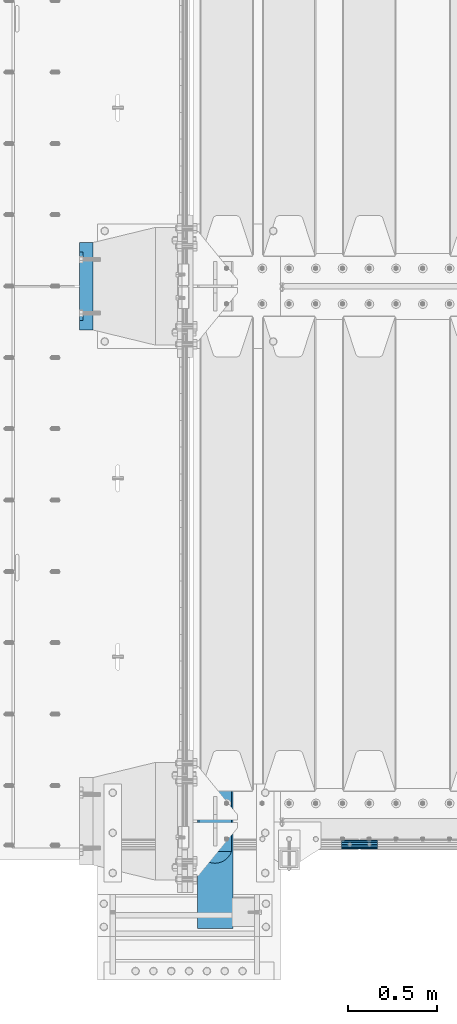
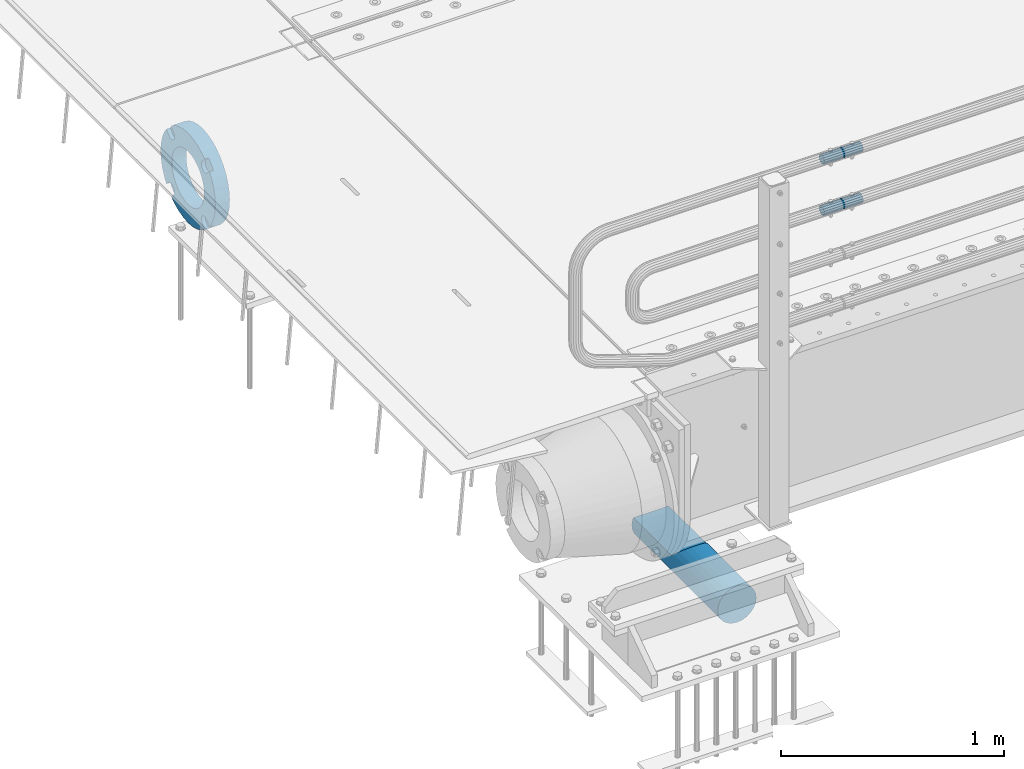
# One storey, part 132 of 240: 4 beams.
"""IFC2X3 building model written with IfcOpenShell, lengths in millimetres."""

from ifc_helpers import new_model, si_unit, frame, origin_with_axes, place, context, subcontext, project, spatial, faceted_brep, material, type_object, element, save


model = new_model("IFC2X3")

# Units and contexts
model_context = context("Model", 3, precision=1e-05, world=origin_with_axes())
body_context = subcontext(model_context, "Body", "Model", "MODEL_VIEW")
ifc_project = project(units=[si_unit("LENGTHUNIT", "METRE", prefix="MILLI"), si_unit("AREAUNIT", "SQUARE_METRE"), si_unit("VOLUMEUNIT", "CUBIC_METRE"), si_unit("MASSUNIT", "GRAM", prefix="KILO"), si_unit("TIMEUNIT", "SECOND"), si_unit("PLANEANGLEUNIT", "RADIAN"), si_unit("SOLIDANGLEUNIT", "STERADIAN"), si_unit("THERMODYNAMICTEMPERATUREUNIT", "DEGREE_CELSIUS"), si_unit("LUMINOUSINTENSITYUNIT", "LUMEN")], contexts=[model_context])

# Site, building, storey
site_placement = place(None, origin_with_axes())
site = spatial("IfcSite", under=ifc_project, at=site_placement, CompositionType="ELEMENT")
building_placement = place(site_placement, origin_with_axes())
building = spatial("IfcBuilding", under=site, at=building_placement, Name="Standard", CompositionType="ELEMENT")
storey_placement = place(building_placement, origin_with_axes())
storey = spatial("IfcBuildingStorey", under=building, at=storey_placement, Name="Undefined", CompositionType="ELEMENT", Elevation=0.0)

# Beams
ifc_material_1 = material(Name="STEEL/S355N")
beam_type_1 = type_object("IfcBeamType", Name="D200", PredefinedType="NOTDEFINED")
beam_1_placement = place(storey_placement, frame((42585.0, 23400.0, -928.0), z_axis=(0.0, 0.0, 1.0), x_axis=(0.0, 1.0, 0.0)))
element("IfcBeam", 1, at=beam_1_placement, inside=storey, type_object=beam_type_1, material=ifc_material_1, ObjectType="D200", context=body_context, shape_type="Brep", body=[
    faceted_brep([(417.294117647063, 86.6025403784442, 50.0), (395.365164344956, 70.7106781186521, 70.7106781186548), (378.538486658123, 50.0, 86.6025403784439), (367.960794863517, 25.88190451025, 96.5925826289068), (364.352941176476, 0.0, 100.0), (367.960794863517, -25.88190451025, 96.5925826289068), (378.538486658123, -50.0, 86.6025403784439), (395.365164344956, -70.7106781186521, 70.7106781186548), (417.294117647063, -86.6025403784442, 50.0), (430.0, -91.5731031269243, 38.0), (430.0, 91.5731031269243, 38.0), (770.0, -91.5731031269243, 37.9999999999994), (770.0, 91.5731031269243, 37.9999999999994), (0.0, -96.5925826289094, 25.8819045102521), (0.0, -86.6025403784442, 50.0), (0.0, -70.7106781186521, 70.7106781186548), (0.0, -50.0, 86.6025403784439), (0.0, -25.88190451025, 96.5925826289068), (0.0, 0.0, 100.0), (0.0, 25.88190451025, 96.5925826289068), (0.0, 50.0, 86.6025403784439), (0.0, 70.7106781186521, 70.7106781186548), (0.0, 86.6025403784442, 50.0), (0.0, 96.5925826289094, 25.8819045102521), (0.0, 100.0, 0.0), (0.0, 96.5925826289094, -25.8819045102521), (0.0, 86.6025403784442, -50.0), (0.0, 70.7106781186521, -70.7106781186548), (0.0, 50.0, -86.6025403784438), (0.0, 25.88190451025, -96.5925826289067), (0.0, 0.0, -100.0), (0.0, -25.88190451025, -96.5925826289069), (0.0, -50.0, -86.6025403784439), (0.0, -70.7106781186521, -70.7106781186548), (0.0, -86.6025403784442, -50.0), (0.0, -96.5925826289094, -25.8819045102522), (0.0, -100.0, 0.0), (770.0, 96.5925826289094, 25.8819045102521), (770.0, 100.0, 0.0), (770.0, 96.5925826289094, -25.8819045102521), (770.0, 86.6025403784442, -50.0), (770.0, 70.7106781186521, -70.7106781186548), (770.0, 50.0, -86.6025403784438), (770.0, 25.88190451025, -96.5925826289067), (770.0, 0.0, -100.0), (770.0, -25.88190451025, -96.5925826289069), (770.0, -50.0, -86.6025403784439), (770.0, -70.7106781186521, -70.7106781186548), (770.0, -86.6025403784442, -50.0), (770.0, -96.5925826289094, -25.8819045102522), (770.0, -100.0, 0.0), (770.0, -96.5925826289094, 25.8819045102521)], [[[0, 1, 2, 3, 4, 5, 6, 7, 8, 9, 10]], [[10, 9, 11, 12]], [[13, 14, 15, 16, 17, 18, 19, 20, 21, 22, 23, 24, 25, 26, 27, 28, 29, 30, 31, 32, 33, 34, 35, 36]], [[24, 23, 37, 38]], [[25, 24, 38, 39]], [[26, 25, 39, 40]], [[27, 26, 40, 41]], [[28, 27, 41, 42]], [[29, 28, 42, 43]], [[30, 29, 43, 44]], [[31, 30, 44, 45]], [[32, 31, 45, 46]], [[33, 32, 46, 47]], [[34, 33, 47, 48]], [[35, 34, 48, 49]], [[36, 35, 49, 50]], [[13, 36, 50, 51]], [[14, 13, 51, 11, 9, 8]], [[15, 14, 8, 7]], [[16, 15, 7, 6]], [[17, 16, 6, 5]], [[18, 17, 5, 4]], [[19, 18, 4, 3]], [[20, 19, 3, 2]], [[21, 20, 2, 1]], [[22, 21, 1, 0]], [[37, 23, 22, 0, 10, 12]], [[51, 50, 49, 48, 47, 46, 45, 44, 43, 42, 41, 40, 39, 38, 37, 12, 11]]]),
])
ifc_material_2 = material()
beam_type_2 = type_object("IfcBeamType", PredefinedType="NOTDEFINED")
beam_2_placement = place(storey_placement, frame((43294.9975029999, 23870.1500000004, 969.849999999747), z_axis=(0.0, 0.0, 1.0), x_axis=(1.0, 0.0, 0.0)))
element("IfcBeam", 2, at=beam_2_placement, inside=storey, type_object=beam_type_2, material=ifc_material_2, context=body_context, shape_type="Brep", body=[
    faceted_brep([(0.0, -21.9000000000015, 0.0), (0.0, -20.232961761998, 8.38076716879547), (200.0, -20.232961761998, 8.38076716879547), (200.0, -21.9000000000015, 0.0), (0.0, -15.4856385079838, 15.4856385079854), (200.0, -15.4856385079838, 15.4856385079854), (0.0, -8.38076716879732, 20.2329617619972), (200.0, -8.38076716879732, 20.2329617619972), (0.0, 0.0, 21.9), (200.0, 0.0, 21.9), (0.0, 8.38076716879732, 20.2329617619972), (200.0, 8.38076716879732, 20.2329617619972), (0.0, 15.4856385079838, 15.4856385079854), (200.0, 15.4856385079838, 15.4856385079854), (0.0, 20.232961761998, 8.38076716879547), (200.0, 20.232961761998, 8.38076716879547), (0.0, 21.9000000000015, 0.0), (200.0, 21.9000000000015, 0.0), (0.0, 20.232961761998, -8.38076716879547), (200.0, 20.232961761998, -8.38076716879547), (0.0, 15.4856385079838, -15.4856385079854), (200.0, 15.4856385079838, -15.4856385079854), (0.0, 8.38076716879732, -20.2329617619972), (200.0, 8.38076716879732, -20.2329617619972), (0.0, 0.0, -21.9), (200.0, 0.0, -21.9), (0.0, -8.38076716879732, -20.2329617619972), (200.0, -8.38076716879732, -20.2329617619972), (0.0, -15.4856385079838, -15.4856385079854), (200.0, -15.4856385079838, -15.4856385079854), (0.0, -20.232961761998, -8.38076716879547), (200.0, -20.232961761998, -8.38076716879547), (0.0, -25.5, 0.0), (0.0, -23.5589280790373, -9.7584275253098), (200.0, -23.5589280790373, -9.7584275253098), (200.0, -25.5, 0.0), (0.0, -18.0312229202536, -18.031222920257), (200.0, -18.0312229202536, -18.031222920257), (0.0, -9.75842752531025, -23.5589280790378), (200.0, -9.75842752531025, -23.5589280790378), (0.0, 0.0, -25.5), (200.0, 0.0, -25.5), (0.0, 9.75842752531025, -23.5589280790378), (200.0, 9.75842752531025, -23.5589280790378), (0.0, 18.0312229202536, -18.031222920257), (200.0, 18.0312229202536, -18.031222920257), (0.0, 23.5589280790373, -9.7584275253098), (200.0, 23.5589280790373, -9.7584275253098), (0.0, 25.5, 0.0), (200.0, 25.5, 0.0), (0.0, 23.5589280790373, 9.7584275253098), (200.0, 23.5589280790373, 9.7584275253098), (0.0, 18.0312229202536, 18.031222920257), (200.0, 18.0312229202536, 18.031222920257), (0.0, 9.75842752531025, 23.5589280790378), (200.0, 9.75842752531025, 23.5589280790378), (0.0, 0.0, 25.5), (200.0, 0.0, 25.5), (0.0, -9.75842752531025, 23.5589280790378), (200.0, -9.75842752531025, 23.5589280790378), (0.0, -18.0312229202536, 18.031222920257), (200.0, -18.0312229202536, 18.031222920257), (0.0, -23.5589280790373, 9.7584275253098), (200.0, -23.5589280790373, 9.7584275253098)], [[[0, 1, 2, 3]], [[1, 4, 5, 2]], [[4, 6, 7, 5]], [[6, 8, 9, 7]], [[8, 10, 11, 9]], [[10, 12, 13, 11]], [[12, 14, 15, 13]], [[14, 16, 17, 15]], [[16, 18, 19, 17]], [[18, 20, 21, 19]], [[20, 22, 23, 21]], [[22, 24, 25, 23]], [[24, 26, 27, 25]], [[26, 28, 29, 27]], [[28, 30, 31, 29]], [[30, 0, 3, 31]], [[32, 33, 34, 35]], [[33, 36, 37, 34]], [[36, 38, 39, 37]], [[38, 40, 41, 39]], [[40, 42, 43, 41]], [[42, 44, 45, 43]], [[44, 46, 47, 45]], [[46, 48, 49, 47]], [[48, 50, 51, 49]], [[50, 52, 53, 51]], [[52, 54, 55, 53]], [[54, 56, 57, 55]], [[56, 58, 59, 57]], [[58, 60, 61, 59]], [[60, 62, 63, 61]], [[62, 32, 35, 63]], [[37, 39, 41, 43, 45, 47, 49, 51, 53, 55, 57, 59, 61, 63, 35, 34], [5, 7, 9, 11, 13, 15, 17, 19, 21, 23, 25, 27, 29, 31, 3, 2]], [[62, 60, 58, 56, 54, 52, 50, 48, 46, 44, 42, 40, 38, 36, 33, 32], [30, 28, 26, 24, 22, 20, 18, 16, 14, 12, 10, 8, 6, 4, 1, 0]]]),
])
beam_3_placement = place(storey_placement, frame((43294.9975029999, 23870.1500000004, 689.849999999747), z_axis=(0.0, 0.0, 1.0), x_axis=(1.0, 0.0, 0.0)))
element("IfcBeam", 3, at=beam_3_placement, inside=storey, type_object=beam_type_2, material=ifc_material_2, context=body_context, shape_type="Brep", body=[
    faceted_brep([(0.0, -21.9000000000015, 0.0), (0.0, -20.232961761998, 8.38076716879547), (200.0, -20.232961761998, 8.38076716879547), (200.0, -21.9000000000015, 0.0), (0.0, -15.4856385079838, 15.4856385079854), (200.0, -15.4856385079838, 15.4856385079854), (0.0, -8.38076716879732, 20.2329617619972), (200.0, -8.38076716879732, 20.2329617619972), (0.0, 0.0, 21.9), (200.0, 0.0, 21.9), (0.0, 8.38076716879732, 20.2329617619972), (200.0, 8.38076716879732, 20.2329617619972), (0.0, 15.4856385079838, 15.4856385079854), (200.0, 15.4856385079838, 15.4856385079854), (0.0, 20.232961761998, 8.38076716879547), (200.0, 20.232961761998, 8.38076716879547), (0.0, 21.9000000000015, 0.0), (200.0, 21.9000000000015, 0.0), (0.0, 20.232961761998, -8.38076716879547), (200.0, 20.232961761998, -8.38076716879547), (0.0, 15.4856385079838, -15.4856385079854), (200.0, 15.4856385079838, -15.4856385079854), (0.0, 8.38076716879732, -20.2329617619972), (200.0, 8.38076716879732, -20.2329617619972), (0.0, 0.0, -21.9), (200.0, 0.0, -21.9), (0.0, -8.38076716879732, -20.2329617619972), (200.0, -8.38076716879732, -20.2329617619972), (0.0, -15.4856385079838, -15.4856385079854), (200.0, -15.4856385079838, -15.4856385079854), (0.0, -20.232961761998, -8.38076716879547), (200.0, -20.232961761998, -8.38076716879547), (0.0, -25.5, 0.0), (0.0, -23.5589280790373, -9.7584275253098), (200.0, -23.5589280790373, -9.7584275253098), (200.0, -25.5, 0.0), (0.0, -18.0312229202536, -18.031222920257), (200.0, -18.0312229202536, -18.031222920257), (0.0, -9.75842752531025, -23.5589280790378), (200.0, -9.75842752531025, -23.5589280790378), (0.0, 0.0, -25.5), (200.0, 0.0, -25.5), (0.0, 9.75842752531025, -23.5589280790378), (200.0, 9.75842752531025, -23.5589280790378), (0.0, 18.0312229202536, -18.031222920257), (200.0, 18.0312229202536, -18.031222920257), (0.0, 23.5589280790373, -9.7584275253098), (200.0, 23.5589280790373, -9.7584275253098), (0.0, 25.5, 0.0), (200.0, 25.5, 0.0), (0.0, 23.5589280790373, 9.7584275253098), (200.0, 23.5589280790373, 9.7584275253098), (0.0, 18.0312229202536, 18.031222920257), (200.0, 18.0312229202536, 18.031222920257), (0.0, 9.75842752531025, 23.5589280790378), (200.0, 9.75842752531025, 23.5589280790378), (0.0, 0.0, 25.5), (200.0, 0.0, 25.5), (0.0, -9.75842752531025, 23.5589280790378), (200.0, -9.75842752531025, 23.5589280790378), (0.0, -18.0312229202536, 18.031222920257), (200.0, -18.0312229202536, 18.031222920257), (0.0, -23.5589280790373, 9.7584275253098), (200.0, -23.5589280790373, 9.7584275253098)], [[[0, 1, 2, 3]], [[1, 4, 5, 2]], [[4, 6, 7, 5]], [[6, 8, 9, 7]], [[8, 10, 11, 9]], [[10, 12, 13, 11]], [[12, 14, 15, 13]], [[14, 16, 17, 15]], [[16, 18, 19, 17]], [[18, 20, 21, 19]], [[20, 22, 23, 21]], [[22, 24, 25, 23]], [[24, 26, 27, 25]], [[26, 28, 29, 27]], [[28, 30, 31, 29]], [[30, 0, 3, 31]], [[32, 33, 34, 35]], [[33, 36, 37, 34]], [[36, 38, 39, 37]], [[38, 40, 41, 39]], [[40, 42, 43, 41]], [[42, 44, 45, 43]], [[44, 46, 47, 45]], [[46, 48, 49, 47]], [[48, 50, 51, 49]], [[50, 52, 53, 51]], [[52, 54, 55, 53]], [[54, 56, 57, 55]], [[56, 58, 59, 57]], [[58, 60, 61, 59]], [[60, 62, 63, 61]], [[62, 32, 35, 63]], [[37, 39, 41, 43, 45, 47, 49, 51, 53, 55, 57, 59, 61, 63, 35, 34], [5, 7, 9, 11, 13, 15, 17, 19, 21, 23, 25, 27, 29, 31, 3, 2]], [[62, 60, 58, 56, 54, 52, 50, 48, 46, 44, 42, 40, 38, 36, 33, 32], [30, 28, 26, 24, 22, 20, 18, 16, 14, 12, 10, 8, 6, 4, 1, 0]]]),
])
ifc_material_3 = material(Name="SCN-500-E2")
beam_type_3 = type_object("IfcBeamType", PredefinedType="NOTDEFINED")
beam_4_placement = place(storey_placement, frame((41900.0, 27000.0000014662, -515.0), z_axis=(0.0, 0.0, 1.0), x_axis=(-1.0, 0.0, 0.0)))
element("IfcBeam", 4, at=beam_4_placement, inside=storey, type_object=beam_type_3, material=ifc_material_3, context=body_context, shape_type="Brep", body=[
    faceted_brep([(75.0, 192.717024793295, -150.290616455866), (75.0, 171.473395903973, -129.046987566545), (55.0, 171.473395903973, -129.046987566545), (55.0, 192.717024793288, -150.290616455862), (75.0, 167.467485559311, -125.685629673395), (55.0, 167.467485559311, -125.685629673395), (75.0, 162.938740320955, -123.070957391003), (55.0, 162.938740320955, -123.070957391003), (75.0, 158.024763821777, -121.282416213472), (55.0, 158.024763821777, -121.282416213472), (75.0, 152.874864751095, -120.374350059435), (55.0, 152.874864751095, -120.374350059435), (75.0, 147.645520186205, -120.374350059479), (55.0, 147.645520186205, -120.374350059479), (75.0, 142.495621115537, -121.282416213595), (55.0, 142.495621115537, -121.282416213595), (75.0, 137.581644616374, -123.070957391204), (55.0, 137.581644616374, -123.070957391204), (75.0, 133.052899378039, -125.685629673665), (55.0, 133.052899378039, -125.685629673665), (75.0, 129.04698903278, -129.046987566545), (55.0, 129.04698903278, -129.046987566545), (75.0, 125.685631139982, -133.05289791162), (55.0, 125.685631139982, -133.05289791162), (75.0, 123.070958857592, -137.581643149926), (55.0, 123.070958857592, -137.581643149926), (75.0, 121.28241768005, -142.49561964906), (55.0, 121.28241768005, -142.49561964906), (75.0, 120.374351525992, -147.64551871968), (55.0, 120.374351525992, -147.64551871968), (75.0, 120.374351525999, -152.874863284513), (55.0, 120.374351525999, -152.874863284513), (75.0, 121.282417680093, -158.024762355132), (55.0, 121.282417680093, -158.024762355132), (75.0, 123.070958857665, -162.938738854251), (55.0, 123.070958857665, -162.938738854251), (75.0, 125.685631140077, -167.467484092545), (55.0, 125.685631140077, -167.467484092545), (75.0, 129.04698903278, -171.473394437738), (55.0, 129.04698903278, -171.473394437738), (55.0, 150.290618180639, -192.717023585594), (75.0, 150.290618180639, -192.717023585596), (55.0, 157.482964373201, -187.68088856415), (55.0, 187.680888564151, -157.482964373202), (75.0, -192.717023585596, 150.290618180639), (75.0, -171.4733929715, 129.046987566545), (55.0, -171.4733929715, 129.046987566545), (55.0, -192.717023585596, 150.290618180638), (75.0, -167.467482626838, 125.685629673395), (55.0, -167.467482626838, 125.685629673395), (75.0, -162.938737388482, 123.070957391003), (55.0, -162.938737388482, 123.070957391003), (75.0, -158.024760889304, 121.282416213472), (55.0, -158.024760889304, 121.282416213472), (75.0, -152.874861818622, 120.374350059435), (55.0, -152.874861818622, 120.374350059435), (75.0, -147.645517253732, 120.374350059479), (55.0, -147.645517253732, 120.374350059479), (75.0, -142.495618183064, 121.282416213595), (55.0, -142.495618183064, 121.282416213595), (75.0, -137.581641683901, 123.070957391204), (55.0, -137.581641683901, 123.070957391204), (75.0, -133.052896445566, 125.685629673665), (55.0, -133.052896445566, 125.685629673665), (75.0, -129.046986100308, 129.046987566545), (55.0, -129.046986100308, 129.046987566545), (75.0, -125.68562820751, 133.05289791162), (55.0, -125.68562820751, 133.05289791162), (75.0, -123.070955925119, 137.581643149926), (55.0, -123.070955925119, 137.581643149926), (75.0, -121.282414747577, 142.49561964906), (55.0, -121.282414747577, 142.49561964906), (75.0, -120.374348593519, 147.64551871968), (55.0, -120.374348593519, 147.64551871968), (75.0, -120.374348593527, 152.874863284513), (55.0, -120.374348593527, 152.874863284513), (75.0, -121.28241474762, 158.024762355132), (55.0, -121.28241474762, 158.024762355132), (75.0, -123.070955925192, 162.938738854251), (55.0, -123.070955925192, 162.938738854251), (75.0, -125.685628207604, 167.467484092545), (55.0, -125.685628207604, 167.467484092545), (75.0, -129.046986100308, 171.473394437738), (55.0, -129.046986100308, 171.473394437738), (55.0, -150.290616455866, 192.717024793292), (75.0, -150.290616455866, 192.717024793295), (75.0, 150.290618180639, 192.717023585596), (75.0, 129.04698903278, 171.473394437739), (55.0, 129.04698903278, 171.473394437739), (55.0, 150.290618180632, 192.717023585593), (75.0, 125.685631139633, 167.467484093078), (55.0, 125.685631139633, 167.467484093078), (75.0, 123.070958857235, 162.938738854723), (55.0, 123.070958857235, 162.938738854723), (75.0, 121.282417679708, 158.024762355545), (55.0, 121.282417679708, 158.024762355545), (75.0, 120.374351525672, 152.874863284862), (55.0, 120.374351525672, 152.874863284862), (75.0, 120.374351525716, 147.645518719972), (55.0, 120.374351525716, 147.645518719972), (75.0, 121.282417679831, 142.495619649306), (55.0, 121.282417679831, 142.495619649306), (75.0, 123.070958857439, 137.581643150138), (55.0, 123.070958857439, 137.581643150138), (75.0, 125.685631139902, 133.052897911806), (55.0, 125.685631139902, 133.052897911806), (75.0, 129.04698903278, 129.046987566546), (55.0, 129.04698903278, 129.046987566546), (75.0, 133.052899377857, 125.685629673749), (55.0, 133.052899377857, 125.685629673749), (75.0, 137.581644616163, 123.070957391354), (55.0, 137.581644616163, 123.070957391354), (75.0, 142.495621115297, 121.282416213815), (55.0, 142.495621115297, 121.282416213815), (75.0, 147.645520185913, 120.374350059761), (55.0, 147.645520185913, 120.374350059761), (75.0, 152.874864750745, 120.374350059768), (55.0, 152.874864750745, 120.374350059768), (75.0, 158.02476382137, 121.282416213859), (55.0, 158.02476382137, 121.282416213859), (75.0, 162.938740320489, 123.070957391429), (55.0, 162.938740320489, 123.070957391429), (75.0, 167.46748555878, 125.685629673842), (55.0, 167.46748555878, 125.685629673842), (75.0, 171.473395903973, 129.046987566546), (55.0, 171.473395903973, 129.046987566546), (55.0, 192.717024793288, 150.290616455864), (75.0, 192.717024793295, 150.290616455871), (0.0, 212.176223927185, -122.5), (0.0, 230.224692092546, -83.7949351147888), (75.0, 230.224692092546, -83.7949351147888), (75.0, 212.176223927185, -122.5), (0.0, 241.277899487992, -42.5438035283978), (75.0, 241.277899487992, -42.5438035283978), (0.0, 245.0, 0.0), (75.0, 245.0, 0.0), (0.0, 241.277899487992, 42.543803528398), (75.0, 241.277899487992, 42.543803528398), (0.0, 230.224692092546, 83.7949351147889), (75.0, 230.224692092546, 83.7949351147889), (0.0, 212.176223927185, 122.5), (75.0, 212.176223927185, 122.5), (0.0, 187.680888564151, 157.482964373202), (55.0, 187.680888564151, 157.482964373202), (0.0, 157.482964373201, 187.68088856415), (55.0, 157.482964373201, 187.68088856415), (0.0, 122.5, 212.176223927187), (75.0, 122.5, 212.176223927187), (0.0, 83.7949351147909, 230.224692092548), (75.0, 83.7949351147909, 230.224692092548), (0.0, 42.5438035283951, 241.277899487991), (75.0, 42.5438035283951, 241.277899487991), (0.0, 0.0, 245.0), (75.0, 0.0, 245.0), (0.0, -42.5438035283951, 241.277899487991), (75.0, -42.5438035283951, 241.277899487991), (0.0, -83.7949351147909, 230.224692092548), (75.0, -83.7949351147909, 230.224692092548), (0.0, -122.5, 212.176223927187), (75.0, -122.5, 212.176223927187), (0.0, -157.482964373201, 187.68088856415), (55.0, -157.482964373201, 187.68088856415), (0.0, -187.680888564151, 157.482964373202), (55.0, -187.680888564151, 157.482964373202), (0.0, -212.176223927185, 122.5), (75.0, -212.176223927185, 122.5), (0.0, -230.224692092546, 83.7949351147888), (75.0, -230.224692092546, 83.7949351147888), (0.0, -241.277899487992, 42.5438035283979), (75.0, -241.277899487992, 42.5438035283979), (0.0, -245.0, 0.0), (75.0, -245.0, 0.0), (0.0, -187.680888564151, -157.482964373202), (0.0, -157.482964373201, -187.68088856415), (55.0, -157.482964373201, -187.68088856415), (55.0, -187.680888564151, -157.482964373202), (0.0, 83.7949351147909, -230.224692092547), (0.0, 122.5, -212.176223927187), (75.0, 122.5, -212.176223927187), (75.0, 83.7949351147909, -230.224692092547), (0.0, 42.5438035283951, -241.277899487991), (75.0, 42.5438035283951, -241.277899487991), (0.0, 0.0, -245.0), (75.0, 0.0, -245.0), (0.0, -42.5438035283951, -241.277899487991), (75.0, -42.5438035283951, -241.277899487991), (0.0, -83.7949351147909, -230.224692092548), (75.0, -83.7949351147909, -230.224692092548), (0.0, -122.5, -212.176223927187), (75.0, -122.5, -212.176223927187), (75.0, -150.290616455866, -192.717024793295), (55.0, -150.290616455866, -192.717024793296), (55.0, -129.046986100308, -171.473394437739), (55.0, -125.68562820716, -167.467484093078), (55.0, -123.070955924763, -162.938738854723), (55.0, -121.282414747235, -158.024762355545), (55.0, -120.374348593199, -152.874863284861), (55.0, -120.374348593243, -147.645518719972), (55.0, -121.282414747358, -142.495619649306), (55.0, -123.070955924966, -137.581643150138), (55.0, -125.68562820743, -133.052897911806), (55.0, -129.046986100308, -129.046987566546), (55.0, -133.052896445384, -125.685629673749), (55.0, -137.58164168369, -123.070957391354), (55.0, -142.495618182824, -121.282416213815), (55.0, -147.645517253441, -120.374350059761), (55.0, -152.874861818273, -120.374350059768), (55.0, -158.024760888897, -121.282416213859), (55.0, -162.938737388016, -123.070957391429), (55.0, -167.467482626307, -125.685629673842), (55.0, -171.4733929715, -129.046987566546), (55.0, -192.717023585596, -150.290618180638), (75.0, -129.046986100308, -171.473394437739), (75.0, -125.68562820716, -167.467484093078), (75.0, -123.070955924763, -162.938738854723), (75.0, -121.282414747235, -158.024762355545), (75.0, -120.374348593199, -152.874863284861), (75.0, -120.374348593243, -147.645518719972), (75.0, -121.282414747358, -142.495619649306), (75.0, -123.070955924966, -137.581643150138), (75.0, -125.68562820743, -133.052897911806), (75.0, -129.046986100308, -129.046987566546), (75.0, -133.052896445384, -125.685629673749), (75.0, -137.58164168369, -123.070957391354), (75.0, -142.495618182824, -121.282416213815), (75.0, -147.645517253441, -120.374350059761), (75.0, -152.874861818273, -120.374350059768), (75.0, -158.024760888897, -121.282416213859), (75.0, -162.938737388016, -123.070957391429), (75.0, -167.467482626307, -125.685629673842), (75.0, -171.4733929715, -129.046987566546), (75.0, -192.717023585596, -150.29061818064), (75.0, -212.176223927185, -122.5), (0.0, -212.176223927185, -122.5), (0.0, -230.224692092546, -83.794935114789), (75.0, -230.224692092546, -83.794935114789), (0.0, -241.277899487992, -42.5438035283979), (75.0, -241.277899487992, -42.5438035283979), (0.0, 187.680888564151, -157.482964373202), (0.0, 157.482964373201, -187.68088856415), (0.0, -142.797124186771, -25.1789857617049), (0.0, -136.25543001396, -49.592920782222), (0.0, -125.573683548741, -72.5), (0.0, -111.076444252249, -93.2042034045483), (0.0, -93.2042034045517, -111.076444252252), (0.0, -72.5, -125.573683548744), (0.0, -49.5929207822192, -136.255430013957), (0.0, -25.1789857617041, -142.79712418677), (0.0, 0.0, -145.0), (0.0, 25.1789857617041, -142.79712418677), (0.0, 49.5929207822192, -136.255430013957), (0.0, 72.5, -125.573683548744), (0.0, 93.2042034045517, -111.076444252252), (0.0, 111.076444252249, -93.2042034045483), (0.0, 125.573683548741, -72.5), (0.0, 136.25543001396, -49.592920782222), (0.0, 142.797124186771, -25.178985761705), (0.0, 145.0, 0.0), (0.0, 142.797124186771, 25.1789857617048), (0.0, 136.25543001396, 49.5929207822219), (0.0, 125.573683548741, 72.4999999999999), (0.0, 111.076444252249, 93.2042034045482), (0.0, 93.2042034045517, 111.076444252252), (0.0, 72.5, 125.573683548744), (0.0, 49.5929207822192, 136.255430013957), (0.0, 25.1789857617041, 142.79712418677), (0.0, 0.0, 145.0), (0.0, -25.1789857617041, 142.79712418677), (0.0, -49.5929207822192, 136.255430013957), (0.0, -72.5, 125.573683548744), (0.0, -93.2042034045517, 111.076444252252), (0.0, -111.076444252249, 93.2042034045483), (0.0, -125.573683548741, 72.5000000000001), (0.0, -136.25543001396, 49.5929207822221), (0.0, -142.797124186771, 25.1789857617049), (0.0, -145.0, 0.0), (75.0, -145.0, 0.0), (75.0, -142.797124186771, -25.1789857617049), (75.0, -136.25543001396, -49.592920782222), (75.0, -125.573683548741, -72.5), (75.0, -111.076444252249, -93.2042034045483), (75.0, -93.2042034045517, -111.076444252252), (75.0, -72.5, -125.573683548744), (75.0, -49.5929207822192, -136.255430013957), (75.0, -25.1789857617041, -142.79712418677), (75.0, 0.0, -145.0), (75.0, 25.1789857617041, -142.79712418677), (75.0, 49.5929207822192, -136.255430013957), (75.0, 72.5, -125.573683548744), (75.0, 93.2042034045517, -111.076444252252), (75.0, 111.076444252249, -93.2042034045483), (75.0, 125.573683548741, -72.5), (75.0, 136.25543001396, -49.592920782222), (75.0, 142.797124186771, -25.178985761705), (75.0, 145.0, 0.0), (75.0, 142.797124186771, 25.1789857617048), (75.0, 136.25543001396, 49.5929207822219), (75.0, 125.573683548741, 72.4999999999999), (75.0, 111.076444252249, 93.2042034045482), (75.0, 93.2042034045517, 111.076444252252), (75.0, 72.5, 125.573683548744), (75.0, 49.5929207822192, 136.255430013957), (75.0, 25.1789857617041, 142.79712418677), (75.0, 0.0, 145.0), (75.0, -25.1789857617041, 142.79712418677), (75.0, -49.5929207822192, 136.255430013957), (75.0, -72.5, 125.573683548744), (75.0, -93.2042034045517, 111.076444252252), (75.0, -111.076444252249, 93.2042034045483), (75.0, -125.573683548741, 72.5000000000001), (75.0, -136.25543001396, 49.5929207822221), (75.0, -142.797124186771, 25.1789857617049)], [[[0, 1, 2, 3]], [[4, 5, 2, 1]], [[6, 7, 5, 4]], [[8, 9, 7, 6]], [[10, 11, 9, 8]], [[12, 13, 11, 10]], [[14, 15, 13, 12]], [[16, 17, 15, 14]], [[18, 19, 17, 16]], [[20, 21, 19, 18]], [[22, 23, 21, 20]], [[24, 25, 23, 22]], [[26, 27, 25, 24]], [[28, 29, 27, 26]], [[30, 31, 29, 28]], [[32, 33, 31, 30]], [[34, 35, 33, 32]], [[36, 37, 35, 34]], [[38, 39, 37, 36]], [[40, 39, 38, 41]], [[42, 43, 3, 2, 5, 7, 9, 11, 13, 15, 17, 19, 21, 23, 25, 27, 29, 31, 33, 35, 37, 39, 40]], [[44, 45, 46, 47]], [[48, 49, 46, 45]], [[50, 51, 49, 48]], [[52, 53, 51, 50]], [[54, 55, 53, 52]], [[56, 57, 55, 54]], [[58, 59, 57, 56]], [[60, 61, 59, 58]], [[62, 63, 61, 60]], [[64, 65, 63, 62]], [[66, 67, 65, 64]], [[68, 69, 67, 66]], [[70, 71, 69, 68]], [[72, 73, 71, 70]], [[74, 75, 73, 72]], [[76, 77, 75, 74]], [[78, 79, 77, 76]], [[80, 81, 79, 78]], [[82, 83, 81, 80]], [[84, 83, 82, 85]], [[86, 87, 88, 89]], [[90, 91, 88, 87]], [[92, 93, 91, 90]], [[94, 95, 93, 92]], [[96, 97, 95, 94]], [[98, 99, 97, 96]], [[100, 101, 99, 98]], [[102, 103, 101, 100]], [[104, 105, 103, 102]], [[106, 107, 105, 104]], [[108, 109, 107, 106]], [[110, 111, 109, 108]], [[112, 113, 111, 110]], [[114, 115, 113, 112]], [[116, 117, 115, 114]], [[118, 119, 117, 116]], [[120, 121, 119, 118]], [[122, 123, 121, 120]], [[124, 125, 123, 122]], [[126, 125, 124, 127]], [[128, 129, 130, 131]], [[129, 132, 133, 130]], [[132, 134, 135, 133]], [[134, 136, 137, 135]], [[136, 138, 139, 137]], [[138, 140, 141, 139]], [[127, 141, 140, 142, 143, 126]], [[142, 144, 145, 143]], [[89, 88, 91, 93, 95, 97, 99, 101, 103, 105, 107, 109, 111, 113, 115, 117, 119, 121, 123, 125, 126, 143, 145]], [[144, 146, 147, 86, 89, 145]], [[146, 148, 149, 147]], [[148, 150, 151, 149]], [[150, 152, 153, 151]], [[152, 154, 155, 153]], [[154, 156, 157, 155]], [[156, 158, 159, 157]], [[85, 159, 158, 160, 161, 84]], [[160, 162, 163, 161]], [[47, 46, 49, 51, 53, 55, 57, 59, 61, 63, 65, 67, 69, 71, 73, 75, 77, 79, 81, 83, 84, 161, 163]], [[162, 164, 165, 44, 47, 163]], [[164, 166, 167, 165]], [[166, 168, 169, 167]], [[168, 170, 171, 169]], [[172, 173, 174, 175]], [[176, 177, 178, 179]], [[180, 176, 179, 181]], [[182, 180, 181, 183]], [[184, 182, 183, 185]], [[186, 184, 185, 187]], [[188, 186, 187, 189]], [[173, 188, 189, 190, 191, 174]], [[175, 174, 191, 192, 193, 194, 195, 196, 197, 198, 199, 200, 201, 202, 203, 204, 205, 206, 207, 208, 209, 210, 211]], [[190, 212, 192, 191]], [[213, 193, 192, 212]], [[214, 194, 193, 213]], [[215, 195, 194, 214]], [[216, 196, 195, 215]], [[217, 197, 196, 216]], [[218, 198, 197, 217]], [[219, 199, 198, 218]], [[220, 200, 199, 219]], [[221, 201, 200, 220]], [[222, 202, 201, 221]], [[223, 203, 202, 222]], [[224, 204, 203, 223]], [[225, 205, 204, 224]], [[226, 206, 205, 225]], [[227, 207, 206, 226]], [[228, 208, 207, 227]], [[229, 209, 208, 228]], [[230, 210, 209, 229]], [[211, 210, 230, 231]], [[232, 233, 172, 175, 211, 231]], [[234, 233, 232, 235]], [[236, 234, 235, 237]], [[170, 236, 237, 171]], [[168, 166, 164, 162, 160, 158, 156, 154, 152, 150, 148, 146, 144, 142, 140, 138, 136, 134, 132, 129, 128, 238, 239, 177, 176, 180, 182, 184, 186, 188, 173, 172, 233, 234, 236, 170], [240, 241, 242, 243, 244, 245, 246, 247, 248, 249, 250, 251, 252, 253, 254, 255, 256, 257, 258, 259, 260, 261, 262, 263, 264, 265, 266, 267, 268, 269, 270, 271, 272, 273, 274, 275]], [[240, 275, 276, 277]], [[241, 240, 277, 278]], [[242, 241, 278, 279]], [[243, 242, 279, 280]], [[244, 243, 280, 281]], [[245, 244, 281, 282]], [[246, 245, 282, 283]], [[247, 246, 283, 284]], [[248, 247, 284, 285]], [[249, 248, 285, 286]], [[250, 249, 286, 287]], [[251, 250, 287, 288]], [[252, 251, 288, 289]], [[253, 252, 289, 290]], [[254, 253, 290, 291]], [[255, 254, 291, 292]], [[256, 255, 292, 293]], [[257, 256, 293, 294]], [[258, 257, 294, 295]], [[259, 258, 295, 296]], [[260, 259, 296, 297]], [[261, 260, 297, 298]], [[262, 261, 298, 299]], [[263, 262, 299, 300]], [[264, 263, 300, 301]], [[265, 264, 301, 302]], [[266, 265, 302, 303]], [[267, 266, 303, 304]], [[268, 267, 304, 305]], [[269, 268, 305, 306]], [[270, 269, 306, 307]], [[271, 270, 307, 308]], [[272, 271, 308, 309]], [[273, 272, 309, 310]], [[274, 273, 310, 311]], [[275, 274, 311, 276]], [[24, 22, 20, 18, 16, 14, 12, 10, 8, 6, 4, 1, 0, 131, 130, 133, 135, 137, 139, 141, 127, 124, 122, 120, 118, 116, 114, 112, 110, 108, 106, 104, 102, 100, 98, 96, 94, 92, 90, 87, 86, 147, 149, 151, 153, 155, 157, 159, 85, 82, 80, 78, 76, 74, 72, 70, 68, 66, 64, 62, 60, 58, 56, 54, 52, 50, 48, 45, 44, 165, 167, 169, 171, 237, 235, 232, 231, 230, 229, 228, 227, 226, 225, 224, 223, 222, 221, 220, 219, 218, 217, 216, 215, 214, 213, 212, 190, 189, 187, 185, 183, 181, 179, 178, 41, 38, 36, 34, 32, 30, 28, 26], [310, 309, 308, 307, 306, 305, 304, 303, 302, 301, 300, 299, 298, 297, 296, 295, 294, 293, 292, 291, 290, 289, 288, 287, 286, 285, 284, 283, 282, 281, 280, 279, 278, 277, 276, 311]], [[238, 128, 131, 0, 3, 43]], [[239, 238, 43, 42]], [[178, 177, 239, 42, 40, 41]]]),
])

save(model, "model.ifc")
